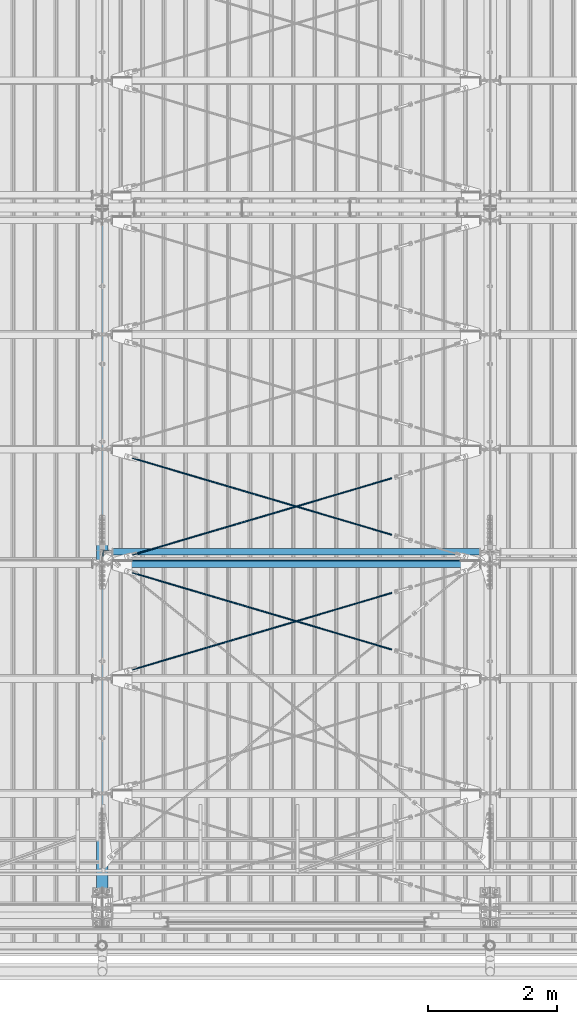
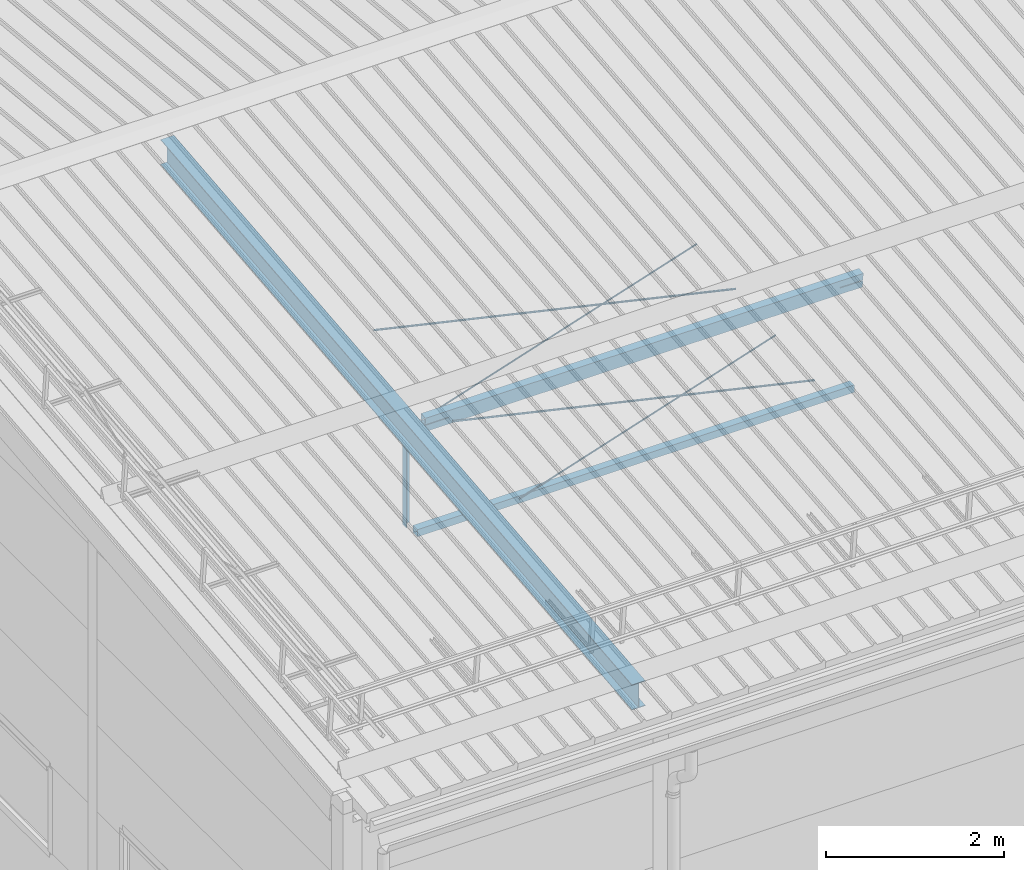
# One storey, part 242 of 709: 8 beams, 6 openings, 8 elements without a shape of their own.
"""IFC4 building model written with IfcOpenShell, lengths in millimetres."""

from ifc_helpers import new_model, si_unit, direction, frame, origin_with_axes, place, context, subcontext, project, spatial, line, indexed_curve, outline, extrude, polygons, material, element, aggregate, save


model = new_model("IFC4")

# Units and contexts
model_context = context("Model", 3, precision=0.2, world=origin_with_axes(), true_north=direction((0.0, 1.0)))
body_context = subcontext(model_context, "Body", "Model", "MODEL_VIEW")
reference_context = subcontext(model_context, "Reference", "Model", "MODEL_VIEW")
ifc_project = project(units=[si_unit("LENGTHUNIT", "METRE", prefix="MILLI"), si_unit("AREAUNIT", "SQUARE_METRE"), si_unit("VOLUMEUNIT", "CUBIC_METRE"), si_unit("MASSUNIT", "GRAM", prefix="KILO"), si_unit("TIMEUNIT", "SECOND"), si_unit("PLANEANGLEUNIT", "RADIAN"), si_unit("SOLIDANGLEUNIT", "STERADIAN"), si_unit("THERMODYNAMICTEMPERATUREUNIT", "DEGREE_CELSIUS"), si_unit("LUMINOUSINTENSITYUNIT", "LUMEN")], contexts=[model_context])

# Site, building, storey
site_placement = place(None, origin_with_axes())
site = spatial("IfcSite", under=ifc_project, at=site_placement, CompositionType="ELEMENT")
building_placement = place(site_placement, origin_with_axes())
building = spatial("IfcBuilding", under=site, at=building_placement, Name="Undefined", CompositionType="ELEMENT")
storey_placement = place(building_placement, origin_with_axes())
storey = spatial("IfcBuildingStorey", under=building, at=storey_placement, Name="Undefined", CompositionType="ELEMENT", Elevation=0.0)

# Assembly, beam
assembly_1_placement = place(storey_placement, frame((4000.0, 346.0, 7089.70002), z_axis=(1.0, 0.0, 0.0), x_axis=(0.0, 0.9950371902, 0.099503719)))
assembly_1 = element("IfcElementAssembly", 1, at=assembly_1_placement, inside=storey)
ifc_material_1 = material(Name="C355-5", Category="STEEL")
beam_1_placement = place(assembly_1_placement, origin_with_axes())
beam_1 = element("IfcBeam", 2, at=beam_1_placement, material=ifc_material_1, ObjectType="432", context=body_context, shape_type="Tessellation", body=[
    polygons([(3.80474, -173.0, -87.0), (4.70474, -164.0, -87.0), (10665.6128, -164.0, -87.0), (10664.7128, -173.0, -87.0), (4.70474, -164.0, -3.0), (10665.6128, -164.0, -3.0), (37.50474, 164.0, -3.0), (10698.4128, 164.0, -3.0), (37.50474, 164.0, -87.0), (10698.4128, 164.0, -87.0), (38.40474, 173.0, -87.0), (10699.3128, 173.0, -87.0), (38.40474, 173.0, 87.0), (10699.3128, 173.0, 87.0), (37.50474, 164.0, 87.0), (10698.4128, 164.0, 87.0), (37.50474, 164.0, 3.0), (10698.4128, 164.0, 3.0), (4.70474, -164.0, 3.0), (10665.6128, -164.0, 3.0), (4.70474, -164.0, 87.0), (10665.6128, -164.0, 87.0), (3.80474, -173.0, 87.0), (10664.7128, -173.0, 87.0)], [[[1, 2, 3, 4]], [[2, 5, 6, 3]], [[5, 7, 8, 6]], [[7, 9, 10, 8]], [[9, 11, 12, 10]], [[11, 13, 14, 12]], [[13, 15, 16, 14]], [[15, 17, 18, 16]], [[17, 19, 20, 18]], [[19, 21, 22, 20]], [[21, 23, 24, 22]], [[23, 1, 4, 24]], [[6, 8, 10, 12, 14, 16, 18, 20, 22, 24, 4, 3]], [[23, 21, 19, 17, 15, 13, 11, 9, 7, 5, 2, 1]]], closed=True),
])
aggregate(assembly_1, [beam_1])

assembly_2_placement = place(storey_placement, frame((4051.0, 5648.7, 7622.40002), z_axis=(0.0, -1.0, 0.0), x_axis=(0.0, 0.0, -1.0)))
assembly_2 = element("IfcElementAssembly", 3, at=assembly_2_placement, inside=storey)
ifc_material_2 = material(Name="C345-5", Category="STEEL")
beam_2_placement = place(assembly_2_placement, origin_with_axes())
beam_2 = element("IfcBeam", 4, at=beam_2_placement, material=ifc_material_2, ObjectType="436", context=body_context, shape_type="Tessellation", body=[
    polygons([(199.0491, -45.0, -45.0), (199.0491, 45.0, -45.0), (1412.4, 45.0, -45.0), (1412.4, -45.0, -45.0), (199.0491, 45.0, -39.0), (1412.4, 45.0, -39.0), (199.0491, -39.0, -39.0), (1412.4, -39.0, -39.0), (199.0491, -39.0, 45.0), (1412.4, -39.0, 45.0), (199.0491, -45.0, 45.0), (1412.4, -45.0, 45.0)], [[[1, 2, 3, 4]], [[2, 5, 6, 3]], [[5, 7, 8, 6]], [[7, 9, 10, 8]], [[9, 11, 12, 10]], [[11, 1, 4, 12]], [[6, 8, 10, 12, 4, 3]], [[11, 9, 7, 5, 2, 1]]], closed=True),
])
aggregate(assembly_2, [beam_2])

assembly_3_placement = place(storey_placement, frame((4000.0, 5673.0, 6074.30002), z_axis=(0.0, -1.0, 0.0), x_axis=(1.0, 0.0, 0.0)))
assembly_3 = element("IfcElementAssembly", 5, at=assembly_3_placement, inside=storey)
ifc_material_3 = material(Name="C355", Category="STEEL")
beam_3_placement = place(assembly_3_placement, origin_with_axes())
beam_3 = element("IfcBeam", 6, at=beam_3_placement, material=ifc_material_3, ObjectType="557", context=body_context, shape_type="Tessellation", body=[
    polygons([(162.0, -47.0, -47.0), (162.0, -47.0, 47.0), (5838.0, -47.0, 47.0), (5838.0, -47.0, -47.0), (162.0, 47.0, 47.0), (5838.0, 47.0, 47.0), (162.0, 47.0, -47.0), (5838.0, 47.0, -47.0), (162.0, -50.0, -50.0), (162.0, 50.0, -50.0), (5838.0, 50.0, -50.0), (5838.0, -50.0, -50.0), (162.0, 50.0, 50.0), (5838.0, 50.0, 50.0), (162.0, -50.0, 50.0), (5838.0, -50.0, 50.0)], [[[1, 2, 3, 4]], [[2, 5, 6, 3]], [[5, 7, 8, 6]], [[7, 1, 4, 8]], [[9, 10, 11, 12]], [[10, 13, 14, 11]], [[13, 15, 16, 14]], [[15, 9, 12, 16]], [[14, 16, 12, 11], [6, 8, 4, 3]], [[15, 13, 10, 9], [7, 5, 2, 1]]], closed=True),
])
aggregate(assembly_3, [beam_3])

# Assembly, beam, voiding feature
assembly_4_placement = place(storey_placement, frame((4000.0, 3712.55385, 7507.7594), z_axis=(0.2852311229, -0.9537021177, -0.0953702118), x_axis=(0.9584587662, 0.2838155751, 0.028381558)))
assembly_4 = element("IfcElementAssembly", 7, at=assembly_4_placement, inside=storey)
beam_4_placement = place(assembly_4_placement, origin_with_axes())
beam_4 = element("IfcBeam", 8, at=beam_4_placement, material=ifc_material_1, ObjectType="570", context=body_context, shape_type="Tessellation", body=[
    polygons([(4850.05021, 7.36122, 4.25), (4850.05021, 6.01041, 6.01041), (4850.05021, 4.25, 7.36121), (4850.05021, 2.19996, 8.21037), (4850.05021, 0.0, 8.5), (4850.05021, -2.19996, 8.21037), (4850.05021, -4.25, 7.36121), (4850.05021, -6.01041, 6.01041), (4850.05021, -7.36121, 4.25), (4850.05021, -8.21037, 2.19996), (4850.05021, -8.5, 0.0), (4850.05021, -8.21037, -2.19996), (4850.05021, -7.36121, -4.25), (4850.05021, -6.01041, -6.01041), (4850.05021, -4.25, -7.36122), (4850.05021, -2.19996, -8.21037), (4850.05021, 0.0, -8.5), (4850.05021, 2.19996, -8.21037), (4850.05021, 4.25, -7.36122), (4850.05021, 6.01041, -6.01041), (4850.05021, 7.36122, -4.25), (4850.05021, 8.21037, -2.19996), (4850.05021, 8.5, 0.0), (4850.05021, 8.21037, 2.19996), (4670.05021, 8.21037, 2.19996), (4670.05021, 7.36122, 4.25), (4670.05021, 6.01041, 6.01041), (4670.05021, 4.25, 7.36121), (4670.05021, 2.19996, 8.21037), (4670.05021, 0.0, 8.5), (4670.05021, -2.19996, 8.21037), (4670.05021, -4.25, 7.36121), (4670.05021, -6.01041, 6.01041), (4670.05021, -7.36121, 4.25), (4670.05021, -8.21037, 2.19996), (4670.05021, -8.5, 0.0), (4670.05021, -8.21037, -2.19996), (4670.05021, -7.36121, -4.25), (4670.05021, -6.01041, -6.01041), (4670.05021, -4.25, -7.36122), (4670.05021, -2.19996, -8.21037), (4670.05021, 0.0, -8.5), (4670.05021, 2.19996, -8.21037), (4670.05021, 4.25, -7.36122), (4670.05021, 6.01041, -6.01041), (4670.05021, 7.36122, -4.25), (4670.05021, 8.21037, -2.19996), (4670.05021, 8.5, 0.0), (4670.05021, 10.0, 0.0), (4670.05021, 9.65926, 2.58819), (4670.05021, 8.66025, 5.0), (4670.05021, 7.07107, 7.07107), (4670.05021, 5.0, 8.66025), (4670.05021, 2.58819, 9.65926), (4670.05021, 0.0, 10.0), (4670.05021, -2.58819, 9.65926), (4670.05021, -5.0, 8.66025), (4670.05021, -7.07107, 7.07107), (4670.05021, -8.66025, 5.0), (4670.05021, -9.65926, 2.58819), (4670.05021, -10.0, 0.0), (4670.05021, -9.65926, -2.58819), (4670.05021, -8.66025, -5.0), (4670.05021, -7.07107, -7.07107), (4670.05021, -5.0, -8.66025), (4670.05021, -2.58819, -9.65926), (4670.05021, 0.0, -10.0), (4670.05021, 2.58819, -9.65926), (4670.05021, 5.0, -8.66025), (4670.05021, 7.07107, -7.07107), (4670.05021, 8.66025, -5.0), (4670.05021, 9.65926, -2.58819), (483.0251, 2.58819, 9.65926), (483.0251, 5.0, 8.66025), (483.0251, 7.07107, 7.07107), (483.0251, 8.66025, 5.0), (483.0251, 9.65926, 2.58819), (483.0251, 10.0, 0.0), (483.0251, 9.65926, -2.58819), (483.0251, 8.66025, -5.0), (483.0251, 7.07107, -7.07107), (483.0251, 5.0, -8.66025), (483.0251, 2.58819, -9.65926), (483.0251, 0.0, -10.0), (483.0251, -2.58819, -9.65926), (483.0251, -5.0, -8.66025), (483.0251, -7.07107, -7.07107), (483.0251, -8.66025, -5.0), (483.0251, -9.65926, -2.58819), (483.0251, -10.0, 0.0), (483.0251, -9.65926, 2.58819), (483.0251, -8.66025, 5.0), (483.0251, -7.07107, 7.07107), (483.0251, -5.0, 8.66025), (483.0251, -2.58819, 9.65926), (483.0251, 0.0, 10.0)], [[[1, 2, 3, 4, 5, 6, 7, 8, 9, 10, 11, 12, 13, 14, 15, 16, 17, 18, 19, 20, 21, 22, 23, 24]], [[24, 25, 26, 1]], [[1, 26, 27, 2]], [[2, 27, 28, 3]], [[3, 28, 29, 4]], [[4, 29, 30, 5]], [[5, 30, 31, 6]], [[6, 31, 32, 7]], [[7, 32, 33, 8]], [[8, 33, 34, 9]], [[9, 34, 35, 10]], [[10, 35, 36, 11]], [[11, 36, 37, 12]], [[12, 37, 38, 13]], [[13, 38, 39, 14]], [[14, 39, 40, 15]], [[15, 40, 41, 16]], [[16, 41, 42, 17]], [[17, 42, 43, 18]], [[18, 43, 44, 19]], [[19, 44, 45, 20]], [[20, 45, 46, 21]], [[21, 46, 47, 22]], [[22, 47, 48, 23]], [[23, 48, 25, 24]], [[49, 50, 51, 52, 53, 54, 55, 56, 57, 58, 59, 60, 61, 62, 63, 64, 65, 66, 67, 68, 69, 70, 71, 72], [47, 46, 45, 44, 43, 42, 41, 40, 39, 38, 37, 36, 35, 34, 33, 32, 31, 30, 29, 28, 27, 26, 25, 48]], [[73, 74, 75, 76, 77, 78, 79, 80, 81, 82, 83, 84, 85, 86, 87, 88, 89, 90, 91, 92, 93, 94, 95, 96]], [[79, 78, 49, 72]], [[80, 79, 72, 71]], [[81, 80, 71, 70]], [[82, 81, 70, 69]], [[83, 82, 69, 68]], [[84, 83, 68, 67]], [[85, 84, 67, 66]], [[86, 85, 66, 65]], [[87, 86, 65, 64]], [[88, 87, 64, 63]], [[89, 88, 63, 62]], [[90, 89, 62, 61]], [[91, 90, 61, 60]], [[92, 91, 60, 59]], [[93, 92, 59, 58]], [[94, 93, 58, 57]], [[95, 94, 57, 56]], [[96, 95, 56, 55]], [[73, 96, 55, 54]], [[74, 73, 54, 53]], [[75, 74, 53, 52]], [[76, 75, 52, 51]], [[77, 76, 51, 50]], [[78, 77, 50, 49]]], closed=True),
])
voiding_feature_1_placement = place(beam_4_placement, frame((4850.05021, 0.0, 0.0), z_axis=(0.0, 1.0, 0.0), x_axis=(-1.0, 0.0, 0.0)))
element("IfcVoidingFeature", 9, at=voiding_feature_1_placement, cuts=beam_4, PredefinedType="HOLE", context=reference_context, identifier="Reference", shape_type="SolidModel", body=[
    extrude(outline(indexed_curve([(10.5, 0.0), (10.14222, 2.7176), (9.09327, 5.25), (7.42462, 7.42462), (5.25, 9.09327), (2.7176, 10.14222), (0.0, 10.5), (-2.7176, 10.14222), (-5.25, 9.09327), (-7.42462, 7.42462), (-9.09327, 5.25), (-10.14222, 2.7176), (-10.5, 0.0), (-10.14222, -2.7176), (-9.09327, -5.25), (-7.42462, -7.42462), (-5.25, -9.09327), (-2.7176, -10.14222), (0.0, -10.5), (2.7176, -10.14222), (5.25, -9.09327), (7.42462, -7.42462), (9.09327, -5.25), (10.14222, -2.7176)], segments=[line(1, 2, 3, 4, 5, 6, 7, 8, 9, 10, 11, 12, 13, 14, 15, 16, 17, 18, 19, 20, 21, 22, 23, 24, 1)])), frame((0.0, 0.0, 0.0), z_axis=(-1.0, 0.0, 0.0), x_axis=(0.0, 0.0, 1.0)), (0.0, 0.0, -1.0), 180.0),
])
aggregate(assembly_4, [beam_4])

assembly_5_placement = place(storey_placement, frame((4000.0, 5489.2536, 7685.42938), z_axis=(-0.2852311229, -0.9537021177, -0.0953702118), x_axis=(0.9584587662, -0.2838155751, -0.028381558)))
assembly_5 = element("IfcElementAssembly", 10, at=assembly_5_placement, inside=storey)
beam_5_placement = place(assembly_5_placement, origin_with_axes())
beam_5 = element("IfcBeam", 11, at=beam_5_placement, material=ifc_material_1, ObjectType="570", context=body_context, shape_type="Tessellation", body=[
    polygons([(4850.05021, 7.36122, 4.25), (4850.05021, 6.01041, 6.01041), (4850.05021, 4.25, 7.36121), (4850.05021, 2.19996, 8.21037), (4850.05021, 0.0, 8.5), (4850.05021, -2.19996, 8.21037), (4850.05021, -4.25, 7.36121), (4850.05021, -6.01041, 6.01041), (4850.05021, -7.36121, 4.25), (4850.05021, -8.21037, 2.19996), (4850.05021, -8.5, 0.0), (4850.05021, -8.21037, -2.19996), (4850.05021, -7.36121, -4.25), (4850.05021, -6.01041, -6.01041), (4850.05021, -4.25, -7.36122), (4850.05021, -2.19996, -8.21037), (4850.05021, 0.0, -8.5), (4850.05021, 2.19996, -8.21037), (4850.05021, 4.25, -7.36122), (4850.05021, 6.01041, -6.01041), (4850.05021, 7.36122, -4.25), (4850.05021, 8.21037, -2.19996), (4850.05021, 8.5, 0.0), (4850.05021, 8.21037, 2.19996), (4670.05021, 8.21037, 2.19996), (4670.05021, 7.36122, 4.25), (4670.05021, 6.01041, 6.01041), (4670.05021, 4.25, 7.36121), (4670.05021, 2.19996, 8.21037), (4670.05021, 0.0, 8.5), (4670.05021, -2.19996, 8.21037), (4670.05021, -4.25, 7.36121), (4670.05021, -6.01041, 6.01041), (4670.05021, -7.36121, 4.25), (4670.05021, -8.21037, 2.19996), (4670.05021, -8.5, 0.0), (4670.05021, -8.21037, -2.19996), (4670.05021, -7.36121, -4.25), (4670.05021, -6.01041, -6.01041), (4670.05021, -4.25, -7.36122), (4670.05021, -2.19996, -8.21037), (4670.05021, 0.0, -8.5), (4670.05021, 2.19996, -8.21037), (4670.05021, 4.25, -7.36122), (4670.05021, 6.01041, -6.01041), (4670.05021, 7.36122, -4.25), (4670.05021, 8.21037, -2.19996), (4670.05021, 8.5, 0.0), (4670.05021, 10.0, 0.0), (4670.05021, 9.65926, 2.58819), (4670.05021, 8.66025, 5.0), (4670.05021, 7.07107, 7.07107), (4670.05021, 5.0, 8.66025), (4670.05021, 2.58819, 9.65926), (4670.05021, 0.0, 10.0), (4670.05021, -2.58819, 9.65926), (4670.05021, -5.0, 8.66025), (4670.05021, -7.07107, 7.07107), (4670.05021, -8.66025, 5.0), (4670.05021, -9.65926, 2.58819), (4670.05021, -10.0, 0.0), (4670.05021, -9.65926, -2.58819), (4670.05021, -8.66025, -5.0), (4670.05021, -7.07107, -7.07107), (4670.05021, -5.0, -8.66025), (4670.05021, -2.58819, -9.65926), (4670.05021, 0.0, -10.0), (4670.05021, 2.58819, -9.65926), (4670.05021, 5.0, -8.66025), (4670.05021, 7.07107, -7.07107), (4670.05021, 8.66025, -5.0), (4670.05021, 9.65926, -2.58819), (483.0251, 2.58819, 9.65926), (483.0251, 5.0, 8.66025), (483.0251, 7.07107, 7.07107), (483.0251, 8.66025, 5.0), (483.0251, 9.65926, 2.58819), (483.0251, 10.0, 0.0), (483.0251, 9.65926, -2.58819), (483.0251, 8.66025, -5.0), (483.0251, 7.07107, -7.07107), (483.0251, 5.0, -8.66025), (483.0251, 2.58819, -9.65926), (483.0251, 0.0, -10.0), (483.0251, -2.58819, -9.65926), (483.0251, -5.0, -8.66025), (483.0251, -7.07107, -7.07107), (483.0251, -8.66025, -5.0), (483.0251, -9.65926, -2.58819), (483.0251, -10.0, 0.0), (483.0251, -9.65926, 2.58819), (483.0251, -8.66025, 5.0), (483.0251, -7.07107, 7.07107), (483.0251, -5.0, 8.66025), (483.0251, -2.58819, 9.65926), (483.0251, 0.0, 10.0)], [[[1, 2, 3, 4, 5, 6, 7, 8, 9, 10, 11, 12, 13, 14, 15, 16, 17, 18, 19, 20, 21, 22, 23, 24]], [[24, 25, 26, 1]], [[1, 26, 27, 2]], [[2, 27, 28, 3]], [[3, 28, 29, 4]], [[4, 29, 30, 5]], [[5, 30, 31, 6]], [[6, 31, 32, 7]], [[7, 32, 33, 8]], [[8, 33, 34, 9]], [[9, 34, 35, 10]], [[10, 35, 36, 11]], [[11, 36, 37, 12]], [[12, 37, 38, 13]], [[13, 38, 39, 14]], [[14, 39, 40, 15]], [[15, 40, 41, 16]], [[16, 41, 42, 17]], [[17, 42, 43, 18]], [[18, 43, 44, 19]], [[19, 44, 45, 20]], [[20, 45, 46, 21]], [[21, 46, 47, 22]], [[22, 47, 48, 23]], [[23, 48, 25, 24]], [[49, 50, 51, 52, 53, 54, 55, 56, 57, 58, 59, 60, 61, 62, 63, 64, 65, 66, 67, 68, 69, 70, 71, 72], [47, 46, 45, 44, 43, 42, 41, 40, 39, 38, 37, 36, 35, 34, 33, 32, 31, 30, 29, 28, 27, 26, 25, 48]], [[73, 74, 75, 76, 77, 78, 79, 80, 81, 82, 83, 84, 85, 86, 87, 88, 89, 90, 91, 92, 93, 94, 95, 96]], [[79, 78, 49, 72]], [[80, 79, 72, 71]], [[81, 80, 71, 70]], [[82, 81, 70, 69]], [[83, 82, 69, 68]], [[84, 83, 68, 67]], [[85, 84, 67, 66]], [[86, 85, 66, 65]], [[87, 86, 65, 64]], [[88, 87, 64, 63]], [[89, 88, 63, 62]], [[90, 89, 62, 61]], [[91, 90, 61, 60]], [[92, 91, 60, 59]], [[93, 92, 59, 58]], [[94, 93, 58, 57]], [[95, 94, 57, 56]], [[96, 95, 56, 55]], [[73, 96, 55, 54]], [[74, 73, 54, 53]], [[75, 74, 53, 52]], [[76, 75, 52, 51]], [[77, 76, 51, 50]], [[78, 77, 50, 49]]], closed=True),
])
voiding_feature_2_placement = place(beam_5_placement, frame((4850.05021, 0.0, 0.0), z_axis=(0.0, 1.0, 0.0), x_axis=(-1.0, 0.0, 0.0)))
element("IfcVoidingFeature", 12, at=voiding_feature_2_placement, cuts=beam_5, PredefinedType="HOLE", context=reference_context, identifier="Reference", shape_type="SolidModel", body=[
    extrude(outline(indexed_curve([(10.5, 0.0), (10.14222, 2.7176), (9.09327, 5.25), (7.42462, 7.42462), (5.25, 9.09327), (2.7176, 10.14222), (0.0, 10.5), (-2.7176, 10.14222), (-5.25, 9.09327), (-7.42462, 7.42462), (-9.09327, 5.25), (-10.14222, 2.7176), (-10.5, 0.0), (-10.14222, -2.7176), (-9.09327, -5.25), (-7.42462, -7.42462), (-5.25, -9.09327), (-2.7176, -10.14222), (0.0, -10.5), (2.7176, -10.14222), (5.25, -9.09327), (7.42462, -7.42462), (9.09327, -5.25), (10.14222, -2.7176)], segments=[line(1, 2, 3, 4, 5, 6, 7, 8, 9, 10, 11, 12, 13, 14, 15, 16, 17, 18, 19, 20, 21, 22, 23, 24, 1)])), frame((0.0, 0.0, 0.0), z_axis=(-1.0, 0.0, 0.0), x_axis=(0.0, 0.0, 1.0)), (0.0, 0.0, -1.0), 180.0),
])
aggregate(assembly_5, [beam_5])

assembly_6_placement = place(storey_placement, frame((4000.0, 5489.2536, 7685.42938), z_axis=(0.2847296511, -0.9538504697, -0.095385047), x_axis=(0.9586078582, 0.2833165921, 0.028331659)))
assembly_6 = element("IfcElementAssembly", 13, at=assembly_6_placement, inside=storey)
beam_6_placement = place(assembly_6_placement, origin_with_axes())
beam_6 = element("IfcBeam", 14, at=beam_6_placement, material=ifc_material_1, ObjectType="572", context=body_context, shape_type="Tessellation", body=[
    polygons([(4849.07659, 7.36122, 4.25), (4849.07659, 6.01041, 6.01041), (4849.07659, 4.25, 7.36122), (4849.07659, 2.19996, 8.21037), (4849.07659, 0.0, 8.5), (4849.07659, -2.19996, 8.21037), (4849.07659, -4.25, 7.36122), (4849.07659, -6.01041, 6.01041), (4849.07659, -7.36121, 4.25), (4849.07659, -8.21037, 2.19996), (4849.07659, -8.5, 0.0), (4849.07659, -8.21037, -2.19996), (4849.07659, -7.36121, -4.25), (4849.07659, -6.01041, -6.01041), (4849.07659, -4.25, -7.36122), (4849.07659, -2.19996, -8.21037), (4849.07659, 0.0, -8.5), (4849.07659, 2.19996, -8.21037), (4849.07659, 4.25, -7.36122), (4849.07659, 6.01041, -6.01041), (4849.07659, 7.36122, -4.25), (4849.07659, 8.21037, -2.19996), (4849.07659, 8.5, 0.0), (4849.07659, 8.21037, 2.19996), (4669.07659, 8.21037, 2.19996), (4669.07659, 7.36122, 4.25), (4669.07659, 6.01041, 6.01041), (4669.07659, 4.25, 7.36122), (4669.07659, 2.19996, 8.21037), (4669.07659, 0.0, 8.5), (4669.07659, -2.19996, 8.21037), (4669.07659, -4.25, 7.36122), (4669.07659, -6.01041, 6.01041), (4669.07659, -7.36121, 4.25), (4669.07659, -8.21037, 2.19996), (4669.07659, -8.5, 0.0), (4669.07659, -8.21037, -2.19996), (4669.07659, -7.36121, -4.25), (4669.07659, -6.01041, -6.01041), (4669.07659, -4.25, -7.36122), (4669.07659, -2.19996, -8.21037), (4669.07659, 0.0, -8.5), (4669.07659, 2.19996, -8.21037), (4669.07659, 4.25, -7.36122), (4669.07659, 6.01041, -6.01041), (4669.07659, 7.36122, -4.25), (4669.07659, 8.21037, -2.19996), (4669.07659, 8.5, 0.0), (4669.07659, 10.0, 0.0), (4669.07659, 9.65926, 2.58819), (4669.07659, 8.66025, 5.0), (4669.07659, 7.07107, 7.07107), (4669.07659, 5.0, 8.66025), (4669.07659, 2.58819, 9.65926), (4669.07659, 0.0, 10.0), (4669.07659, -2.58819, 9.65926), (4669.07659, -5.0, 8.66025), (4669.07659, -7.07107, 7.07107), (4669.07659, -8.66025, 5.0), (4669.07659, -9.65926, 2.58819), (4669.07659, -10.0, 0.0), (4669.07659, -9.65926, -2.58819), (4669.07659, -8.66025, -5.0), (4669.07659, -7.07107, -7.07107), (4669.07659, -5.0, -8.66025), (4669.07659, -2.58819, -9.65926), (4669.07659, 0.0, -10.0), (4669.07659, 2.58819, -9.65926), (4669.07659, 5.0, -8.66025), (4669.07659, 7.07107, -7.07107), (4669.07659, 8.66025, -5.0), (4669.07659, 9.65926, -2.58819), (483.68279, 2.58819, 9.65926), (483.68279, 5.0, 8.66025), (483.68279, 7.07107, 7.07107), (483.68279, 8.66025, 5.0), (483.68279, 9.65926, 2.58819), (483.68279, 10.0, 0.0), (483.68279, 9.65926, -2.58819), (483.68279, 8.66025, -5.0), (483.68279, 7.07107, -7.07107), (483.68279, 5.0, -8.66025), (483.68279, 2.58819, -9.65926), (483.68279, 0.0, -10.0), (483.68279, -2.58819, -9.65926), (483.68279, -5.0, -8.66025), (483.68279, -7.07107, -7.07107), (483.68279, -8.66025, -5.0), (483.68279, -9.65926, -2.58819), (483.68279, -10.0, 0.0), (483.68279, -9.65926, 2.58819), (483.68279, -8.66025, 5.0), (483.68279, -7.07107, 7.07107), (483.68279, -5.0, 8.66025), (483.68279, -2.58819, 9.65926), (483.68279, 0.0, 10.0)], [[[1, 2, 3, 4, 5, 6, 7, 8, 9, 10, 11, 12, 13, 14, 15, 16, 17, 18, 19, 20, 21, 22, 23, 24]], [[24, 25, 26, 1]], [[1, 26, 27, 2]], [[2, 27, 28, 3]], [[3, 28, 29, 4]], [[4, 29, 30, 5]], [[5, 30, 31, 6]], [[6, 31, 32, 7]], [[7, 32, 33, 8]], [[8, 33, 34, 9]], [[9, 34, 35, 10]], [[10, 35, 36, 11]], [[11, 36, 37, 12]], [[12, 37, 38, 13]], [[13, 38, 39, 14]], [[14, 39, 40, 15]], [[15, 40, 41, 16]], [[16, 41, 42, 17]], [[17, 42, 43, 18]], [[18, 43, 44, 19]], [[19, 44, 45, 20]], [[20, 45, 46, 21]], [[21, 46, 47, 22]], [[22, 47, 48, 23]], [[23, 48, 25, 24]], [[49, 50, 51, 52, 53, 54, 55, 56, 57, 58, 59, 60, 61, 62, 63, 64, 65, 66, 67, 68, 69, 70, 71, 72], [47, 46, 45, 44, 43, 42, 41, 40, 39, 38, 37, 36, 35, 34, 33, 32, 31, 30, 29, 28, 27, 26, 25, 48]], [[73, 74, 75, 76, 77, 78, 79, 80, 81, 82, 83, 84, 85, 86, 87, 88, 89, 90, 91, 92, 93, 94, 95, 96]], [[79, 78, 49, 72]], [[80, 79, 72, 71]], [[81, 80, 71, 70]], [[82, 81, 70, 69]], [[83, 82, 69, 68]], [[84, 83, 68, 67]], [[85, 84, 67, 66]], [[86, 85, 66, 65]], [[87, 86, 65, 64]], [[88, 87, 64, 63]], [[89, 88, 63, 62]], [[90, 89, 62, 61]], [[91, 90, 61, 60]], [[92, 91, 60, 59]], [[93, 92, 59, 58]], [[94, 93, 58, 57]], [[95, 94, 57, 56]], [[96, 95, 56, 55]], [[73, 96, 55, 54]], [[74, 73, 54, 53]], [[75, 74, 53, 52]], [[76, 75, 52, 51]], [[77, 76, 51, 50]], [[78, 77, 50, 49]]], closed=True),
])
voiding_feature_3_placement = place(beam_6_placement, frame((4849.07659, 0.0, 0.0), z_axis=(0.0, 1.0, 0.0), x_axis=(-1.0, 0.0, 0.0)))
element("IfcVoidingFeature", 15, at=voiding_feature_3_placement, cuts=beam_6, PredefinedType="HOLE", context=reference_context, identifier="Reference", shape_type="SolidModel", body=[
    extrude(outline(indexed_curve([(10.5, 0.0), (10.14222, 2.7176), (9.09327, 5.25), (7.42462, 7.42462), (5.25, 9.09327), (2.7176, 10.14222), (0.0, 10.5), (-2.7176, 10.14222), (-5.25, 9.09327), (-7.42462, 7.42462), (-9.09327, 5.25), (-10.14222, 2.7176), (-10.5, 0.0), (-10.14222, -2.7176), (-9.09327, -5.25), (-7.42462, -7.42462), (-5.25, -9.09327), (-2.7176, -10.14222), (0.0, -10.5), (2.7176, -10.14222), (5.25, -9.09327), (7.42462, -7.42462), (9.09327, -5.25), (10.14222, -2.7176)], segments=[line(1, 2, 3, 4, 5, 6, 7, 8, 9, 10, 11, 12, 13, 14, 15, 16, 17, 18, 19, 20, 21, 22, 23, 24, 1)])), frame((0.0, 0.0, 0.0), z_axis=(-1.0, 0.0, 0.0), x_axis=(0.0, 0.0, 1.0)), (0.0, 0.0, -1.0), 180.0),
])
aggregate(assembly_6, [beam_6])

assembly_7_placement = place(storey_placement, frame((4000.0, 7262.55385, 7862.7594), z_axis=(-0.2847296511, -0.9538504697, -0.095385047), x_axis=(0.9586078582, -0.2833165921, -0.028331659)))
assembly_7 = element("IfcElementAssembly", 16, at=assembly_7_placement, inside=storey)
beam_7_placement = place(assembly_7_placement, origin_with_axes())
beam_7 = element("IfcBeam", 17, at=beam_7_placement, material=ifc_material_1, ObjectType="572", context=body_context, shape_type="Tessellation", body=[
    polygons([(4849.07659, 7.36122, 4.25), (4849.07659, 6.01041, 6.01041), (4849.07659, 4.25, 7.36122), (4849.07659, 2.19996, 8.21037), (4849.07659, 0.0, 8.5), (4849.07659, -2.19996, 8.21037), (4849.07659, -4.25, 7.36122), (4849.07659, -6.01041, 6.01041), (4849.07659, -7.36121, 4.25), (4849.07659, -8.21037, 2.19996), (4849.07659, -8.5, 0.0), (4849.07659, -8.21037, -2.19996), (4849.07659, -7.36121, -4.25), (4849.07659, -6.01041, -6.01041), (4849.07659, -4.25, -7.36122), (4849.07659, -2.19996, -8.21037), (4849.07659, 0.0, -8.5), (4849.07659, 2.19996, -8.21037), (4849.07659, 4.25, -7.36122), (4849.07659, 6.01041, -6.01041), (4849.07659, 7.36122, -4.25), (4849.07659, 8.21037, -2.19996), (4849.07659, 8.5, 0.0), (4849.07659, 8.21037, 2.19996), (4669.07659, 8.21037, 2.19996), (4669.07659, 7.36122, 4.25), (4669.07659, 6.01041, 6.01041), (4669.07659, 4.25, 7.36122), (4669.07659, 2.19996, 8.21037), (4669.07659, 0.0, 8.5), (4669.07659, -2.19996, 8.21037), (4669.07659, -4.25, 7.36122), (4669.07659, -6.01041, 6.01041), (4669.07659, -7.36121, 4.25), (4669.07659, -8.21037, 2.19996), (4669.07659, -8.5, 0.0), (4669.07659, -8.21037, -2.19996), (4669.07659, -7.36121, -4.25), (4669.07659, -6.01041, -6.01041), (4669.07659, -4.25, -7.36122), (4669.07659, -2.19996, -8.21037), (4669.07659, 0.0, -8.5), (4669.07659, 2.19996, -8.21037), (4669.07659, 4.25, -7.36122), (4669.07659, 6.01041, -6.01041), (4669.07659, 7.36122, -4.25), (4669.07659, 8.21037, -2.19996), (4669.07659, 8.5, 0.0), (4669.07659, 10.0, 0.0), (4669.07659, 9.65926, 2.58819), (4669.07659, 8.66025, 5.0), (4669.07659, 7.07107, 7.07107), (4669.07659, 5.0, 8.66025), (4669.07659, 2.58819, 9.65926), (4669.07659, 0.0, 10.0), (4669.07659, -2.58819, 9.65926), (4669.07659, -5.0, 8.66025), (4669.07659, -7.07107, 7.07107), (4669.07659, -8.66025, 5.0), (4669.07659, -9.65926, 2.58819), (4669.07659, -10.0, 0.0), (4669.07659, -9.65926, -2.58819), (4669.07659, -8.66025, -5.0), (4669.07659, -7.07107, -7.07107), (4669.07659, -5.0, -8.66025), (4669.07659, -2.58819, -9.65926), (4669.07659, 0.0, -10.0), (4669.07659, 2.58819, -9.65926), (4669.07659, 5.0, -8.66025), (4669.07659, 7.07107, -7.07107), (4669.07659, 8.66025, -5.0), (4669.07659, 9.65926, -2.58819), (483.68279, 2.58819, 9.65926), (483.68279, 5.0, 8.66025), (483.68279, 7.07107, 7.07107), (483.68279, 8.66025, 5.0), (483.68279, 9.65926, 2.58819), (483.68279, 10.0, 0.0), (483.68279, 9.65926, -2.58819), (483.68279, 8.66025, -5.0), (483.68279, 7.07107, -7.07107), (483.68279, 5.0, -8.66025), (483.68279, 2.58819, -9.65926), (483.68279, 0.0, -10.0), (483.68279, -2.58819, -9.65926), (483.68279, -5.0, -8.66025), (483.68279, -7.07107, -7.07107), (483.68279, -8.66025, -5.0), (483.68279, -9.65926, -2.58819), (483.68279, -10.0, 0.0), (483.68279, -9.65926, 2.58819), (483.68279, -8.66025, 5.0), (483.68279, -7.07107, 7.07107), (483.68279, -5.0, 8.66025), (483.68279, -2.58819, 9.65926), (483.68279, 0.0, 10.0)], [[[1, 2, 3, 4, 5, 6, 7, 8, 9, 10, 11, 12, 13, 14, 15, 16, 17, 18, 19, 20, 21, 22, 23, 24]], [[24, 25, 26, 1]], [[1, 26, 27, 2]], [[2, 27, 28, 3]], [[3, 28, 29, 4]], [[4, 29, 30, 5]], [[5, 30, 31, 6]], [[6, 31, 32, 7]], [[7, 32, 33, 8]], [[8, 33, 34, 9]], [[9, 34, 35, 10]], [[10, 35, 36, 11]], [[11, 36, 37, 12]], [[12, 37, 38, 13]], [[13, 38, 39, 14]], [[14, 39, 40, 15]], [[15, 40, 41, 16]], [[16, 41, 42, 17]], [[17, 42, 43, 18]], [[18, 43, 44, 19]], [[19, 44, 45, 20]], [[20, 45, 46, 21]], [[21, 46, 47, 22]], [[22, 47, 48, 23]], [[23, 48, 25, 24]], [[49, 50, 51, 52, 53, 54, 55, 56, 57, 58, 59, 60, 61, 62, 63, 64, 65, 66, 67, 68, 69, 70, 71, 72], [47, 46, 45, 44, 43, 42, 41, 40, 39, 38, 37, 36, 35, 34, 33, 32, 31, 30, 29, 28, 27, 26, 25, 48]], [[73, 74, 75, 76, 77, 78, 79, 80, 81, 82, 83, 84, 85, 86, 87, 88, 89, 90, 91, 92, 93, 94, 95, 96]], [[79, 78, 49, 72]], [[80, 79, 72, 71]], [[81, 80, 71, 70]], [[82, 81, 70, 69]], [[83, 82, 69, 68]], [[84, 83, 68, 67]], [[85, 84, 67, 66]], [[86, 85, 66, 65]], [[87, 86, 65, 64]], [[88, 87, 64, 63]], [[89, 88, 63, 62]], [[90, 89, 62, 61]], [[91, 90, 61, 60]], [[92, 91, 60, 59]], [[93, 92, 59, 58]], [[94, 93, 58, 57]], [[95, 94, 57, 56]], [[96, 95, 56, 55]], [[73, 96, 55, 54]], [[74, 73, 54, 53]], [[75, 74, 53, 52]], [[76, 75, 52, 51]], [[77, 76, 51, 50]], [[78, 77, 50, 49]]], closed=True),
])
voiding_feature_4_placement = place(beam_7_placement, frame((4849.07659, 0.0, 0.0), z_axis=(0.0, 1.0, 0.0), x_axis=(-1.0, 0.0, 0.0)))
element("IfcVoidingFeature", 18, at=voiding_feature_4_placement, cuts=beam_7, PredefinedType="HOLE", context=reference_context, identifier="Reference", shape_type="SolidModel", body=[
    extrude(outline(indexed_curve([(10.5, 0.0), (10.14222, 2.7176), (9.09327, 5.25), (7.42462, 7.42462), (5.25, 9.09327), (2.7176, 10.14222), (0.0, 10.5), (-2.7176, 10.14222), (-5.25, 9.09327), (-7.42462, 7.42462), (-9.09327, 5.25), (-10.14222, 2.7176), (-10.5, 0.0), (-10.14222, -2.7176), (-9.09327, -5.25), (-7.42462, -7.42462), (-5.25, -9.09327), (-2.7176, -10.14222), (0.0, -10.5), (2.7176, -10.14222), (5.25, -9.09327), (7.42462, -7.42462), (9.09327, -5.25), (10.14222, -2.7176)], segments=[line(1, 2, 3, 4, 5, 6, 7, 8, 9, 10, 11, 12, 13, 14, 15, 16, 17, 18, 19, 20, 21, 22, 23, 24, 1)])), frame((0.0, 0.0, 0.0), z_axis=(-1.0, 0.0, 0.0), x_axis=(0.0, 0.0, 1.0)), (0.0, 0.0, -1.0), 180.0),
])
aggregate(assembly_7, [beam_7])

# Assembly, beam, voiding features
assembly_8_placement = place(storey_placement, frame((4000.0, 5490.04963, 7677.46908), z_axis=(0.0, 0.9950371902, 0.099503719), x_axis=(1.0, 0.0, 0.0)))
assembly_8 = element("IfcElementAssembly", 19, at=assembly_8_placement, inside=storey)
beam_8_placement = place(assembly_8_placement, origin_with_axes())
beam_8 = element("IfcBeam", 20, at=beam_8_placement, material=ifc_material_3, ObjectType="566", context=body_context, shape_type="Tessellation", body=[
    polygons([(5845.0, -5.0, 50.0), (5845.0, -5.0, 46.0), (5542.86046, -5.0, 46.0), (5542.84523, -5.0, 50.0), (5542.86046, 5.0, 46.0), (5542.84523, 5.0, 50.0), (5845.00055, 5.0, 50.0), (5845.0, 5.0, 46.0), (5845.0, -5.0, -46.0), (5845.0, -5.0, -50.0), (5543.22591, -5.0, -50.0), (5543.21068, -5.0, -46.0), (5543.22591, 5.0, -50.0), (5543.21068, 5.0, -46.0), (5845.00055, 5.0, -46.0), (5845.0, 5.0, -50.0), (155.0, 96.0, 46.0), (155.0, 96.0, -46.0), (5845.0, 96.0, -46.0), (5845.0, 96.0, 46.0), (5845.0, -96.0, 46.0), (155.0, -96.0, 46.0), (155.0, -5.0, 46.0), (457.13954, -5.0, 46.0), (457.13954, 5.0, 46.0), (155.0, 5.0, 46.0), (155.0, -96.0, -46.0), (5845.0, -96.0, -46.0), (155.0, 5.0, -46.0), (155.0, 5.0, -50.0), (456.7741, 5.0, -50.0), (456.78932, 5.0, -46.0), (456.7741, -5.0, -50.0), (456.78932, -5.0, -46.0), (155.0, -5.0, -50.0), (155.0, -5.0, -46.0), (155.0, -100.0, -50.0), (155.0, -100.0, 50.0), (155.0, -5.0, 50.0), (457.15477, -5.0, 50.0), (457.15477, 5.0, 50.0), (155.0, 5.0, 50.0), (155.0, 100.0, 50.0), (155.0, 100.0, -50.0), (5845.0, 100.0, 50.0), (5845.0, 100.0, -50.0), (5845.0, -100.0, -50.0), (5845.0, -100.0, 50.0)], [[[1, 2, 3, 4]], [[4, 3, 5, 6]], [[7, 6, 5, 8]], [[9, 10, 11, 12]], [[12, 11, 13, 14]], [[15, 14, 13, 16]], [[17, 18, 19, 20]], [[3, 2, 21, 22, 23, 24, 25, 26, 17, 20, 8, 5]], [[27, 22, 21, 28]], [[29, 30, 31, 32]], [[32, 31, 33, 34]], [[34, 33, 35, 36]], [[22, 27, 36, 35, 37, 38, 39, 23]], [[40, 24, 23, 39]], [[41, 25, 24, 40]], [[42, 26, 25, 41]], [[43, 44, 30, 29, 18, 17, 26, 42]], [[44, 43, 45, 46]], [[20, 19, 15, 16, 46, 45, 7, 8]], [[11, 10, 47, 37, 35, 33, 31, 30, 44, 46, 16, 13]], [[38, 37, 47, 48]], [[45, 43, 42, 41, 40, 39, 38, 48, 1, 4, 6, 7]], [[48, 47, 10, 9, 28, 21, 2, 1]], [[19, 18, 29, 32, 34, 36, 27, 28, 9, 12, 14, 15]]], closed=True),
])
voiding_feature_5_placement = place(beam_8_placement, frame((154.99945, 0.0, 92.98165), z_axis=(0.0, -1.0, 0.0), x_axis=(0.0, 0.0, -1.0)))
element("IfcVoidingFeature", 21, at=voiding_feature_5_placement, cuts=beam_8, Name="PLATE", PredefinedType="HOLE", context=reference_context, identifier="Reference", shape_type="SolidModel", body=[
    extrude(outline(indexed_curve([(0.0, 0.0), (186.05886, 0.0), (268.18146, 275.95562), (181.92017, 301.62642), (4.09476, 302.30336), (-82.17995, 276.67769)], segments=[line(1, 2, 3, 4, 5, 6, 1)])), frame((0.0, 0.0, 5.0), z_axis=(0.0, 0.0, 1.0), x_axis=(1.0, 0.0, 0.0)), (0.0, 0.0, -1.0), 10.0),
])
voiding_feature_6_placement = place(beam_8_placement, frame((5845.00055, 0.0, -93.07721), z_axis=(0.0, -1.0, 0.0), x_axis=(0.0, 0.0, 1.0)))
element("IfcVoidingFeature", 22, at=voiding_feature_6_placement, cuts=beam_8, Name="PLATE", PredefinedType="HOLE", context=reference_context, identifier="Reference", shape_type="SolidModel", body=[
    extrude(outline(indexed_curve([(0.0, 0.0), (186.05886, 0.0), (268.2388, 276.67769), (181.9641, 302.30336), (4.13868, 301.62642), (-82.1226, 275.95562)], segments=[line(1, 2, 3, 4, 5, 6, 1)])), frame((0.0, 0.0, 5.0), z_axis=(0.0, 0.0, 1.0), x_axis=(1.0, 0.0, 0.0)), (0.0, 0.0, -1.0), 10.0),
])
aggregate(assembly_8, [beam_8])

save(model, "model.ifc")
